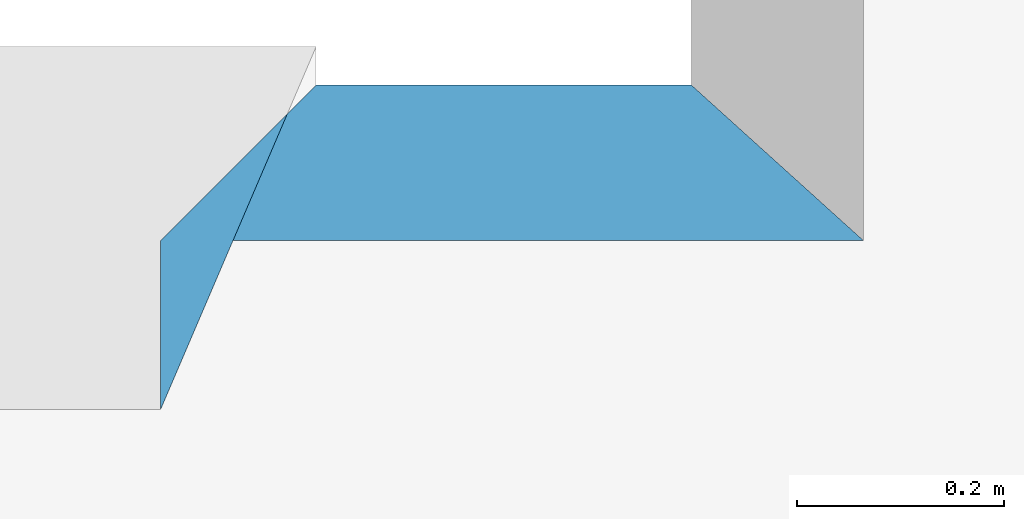
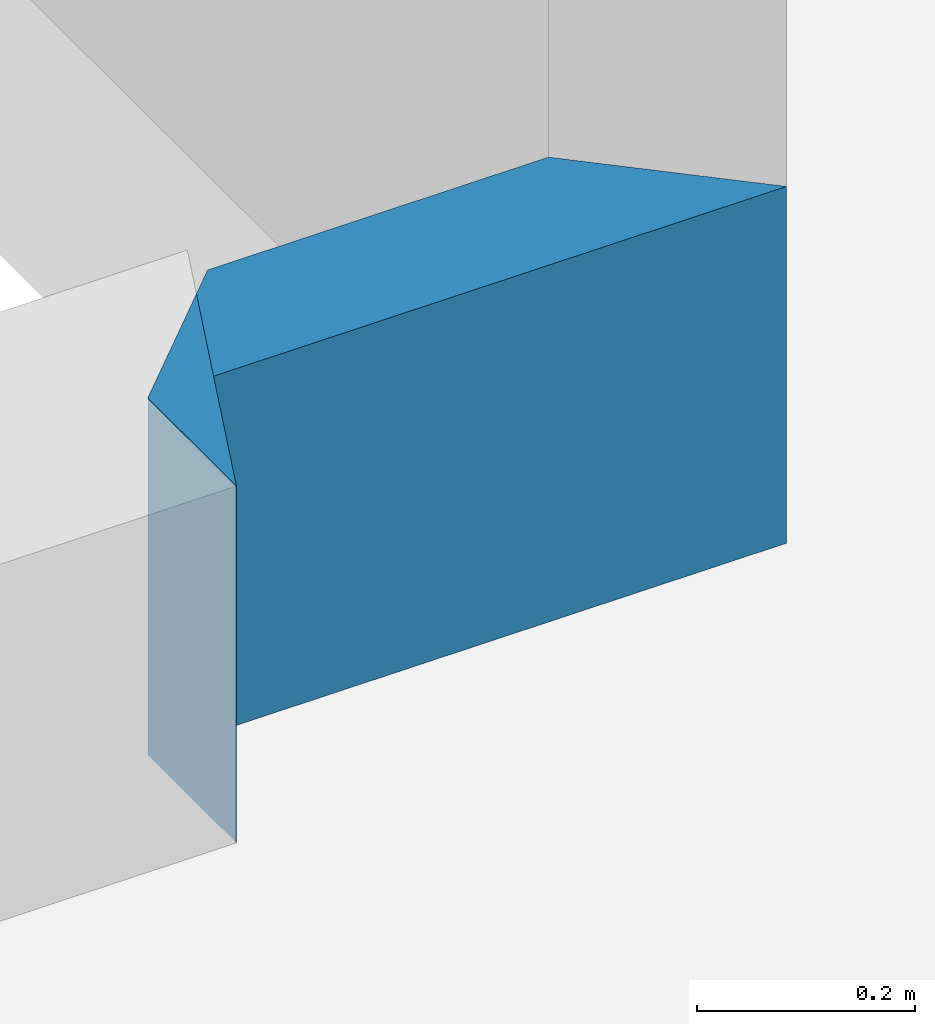
# One storey, part 10 of 72: 2 walls.
"""IFC2X3 building model written with IfcOpenShell, lengths in metres."""

from ifc_helpers import new_model, entity, si_unit, converted_unit, derived_unit, frame, origin_with_axes, place, context, project, spatial, polyline, outline, extrude, material, layer, layer_set, layer_usage, element, save


model = new_model("IFC2X3")

# Units and contexts
context_of_model_1 = context(None, 3, world=origin_with_axes())
context_of_model_2 = context(None, 3, world=origin_with_axes())
context_of_model_3 = context(None, 2, world=origin_with_axes())
context_of_model_4 = context(None, 3, world=origin_with_axes())
ifc_project = project(units=[si_unit("LENGTHUNIT", "METRE"), si_unit("AREAUNIT", "SQUARE_METRE"), si_unit("ELECTRICCURRENTUNIT", "AMPERE"), si_unit("ELECTRICVOLTAGEUNIT", "VOLT"), si_unit("ELECTRICRESISTANCEUNIT", "OHM"), si_unit("POWERUNIT", "WATT"), si_unit("MASSUNIT", "GRAM"), si_unit("SOLIDANGLEUNIT", "STERADIAN"), si_unit("THERMODYNAMICTEMPERATUREUNIT", "KELVIN"), si_unit("PRESSUREUNIT", "PASCAL"), si_unit("LUMINOUSFLUXUNIT", "LUMEN"), si_unit("ILLUMINANCEUNIT", "LUX"), si_unit("FREQUENCYUNIT", "HERTZ"), si_unit("VOLUMEUNIT", "CUBIC_METRE"), si_unit("TIMEUNIT", "SECOND"), derived_unit("VOLUMETRICFLOWRATEUNIT", [(si_unit("TIMEUNIT", "SECOND"), -1), (si_unit("VOLUMEUNIT", "CUBIC_METRE"), 1)]), derived_unit("THERMALTRANSMITTANCEUNIT", [(si_unit("AREAUNIT", "SQUARE_METRE"), -1), (si_unit("THERMODYNAMICTEMPERATUREUNIT", "KELVIN"), -1), (si_unit("POWERUNIT", "WATT"), 1)]), converted_unit("PLANEANGLEUNIT", "DEGREE", entity("IfcPlaneAngleMeasure", 57.29577951308232), si_unit("PLANEANGLEUNIT", "RADIAN"), dimensions=[0, 0, 0, 0, 0, 0, 0])], contexts=[context_of_model_1, context_of_model_2, context_of_model_3, context_of_model_4])

# Site, building, storey
site = spatial("IfcSite", under=ifc_project, CompositionType="ELEMENT")
building_placement = place(None, origin_with_axes())
building = spatial("IfcBuilding", under=site, at=building_placement, Name="200", CompositionType="ELEMENT")
storey_placement = place(building_placement, frame((0.0, 0.0, 15.68000030517578), z_axis=(0.0, 0.0, 1.0), x_axis=(1.0, 0.0, 0.0)))
storey = spatial("IfcBuildingStorey", under=building, at=storey_placement, Name="3.etasje", CompositionType="ELEMENT", Elevation=15.68000030517578)

# Walls
ifc_material = material(Name="Layer-YV3 15 cm")
ifc_layer = layer(ifc_material, 0.1500000059604645, ventilated=False)
ifc_layer_set = layer_set([ifc_layer])
ifc_layer_usage = layer_usage(ifc_layer_set, "AXIS2", "POSITIVE", 0.0)
wall_1_placement = place(storey_placement, frame((-6.411708831787109, 0.09758254885673523, 0.0), z_axis=(0.0, 0.0, 1.0), x_axis=(-1.0, 1.509958025280866e-07, 0.0)))
element("IfcWallStandardCase", 1, at=wall_1_placement, inside=storey, material=ifc_layer_usage, Name="YV3 15 cm", context=context_of_model_1, shape_type="SweptSolid", body=[
    extrude(outline(polyline([(0.0, 0.0), (0.3614883422851585, -3.308722450212111e-24), (0.5114884221944557, 0.1500000102427372), (-0.1659999048319157, 0.1500000149305049), (0.0, 0.0)])), frame((0.0, 0.0, 0.0), z_axis=(0.0, 0.0, 1.0), x_axis=(0.9999999999999989, 4.794156850385361e-08, 0.0)), (0.0, 0.0, 1.0), 0.4),
])
wall_2_placement = place(storey_placement, frame((-6.923197269439697, -0.05241740494966507, 0.0), z_axis=(0.0, 0.0, 1.0), x_axis=(-4.371138828673793e-08, -1.0, 0.0)))
element("IfcWallStandardCase", 2, at=wall_2_placement, inside=storey, material=ifc_layer_usage, Name="YV3 15 cm", context=context_of_model_1, shape_type="SweptSolid", body=[
    extrude(outline(polyline([(0.0, 0.0), (0.1628975495696068, 8.271806125530277e-25), (-0.1871024444699286, 0.1500000953674322), (-0.1499999910593032, 0.150000095367432), (0.0, 0.0)])), frame((0.0, 0.0, 0.0), z_axis=(0.0, 0.0, 1.0), x_axis=(0.999999999999999, 4.3711390674165e-08, 0.0)), (0.0, 0.0, 1.0), 0.4),
])

save(model, "model.ifc")
